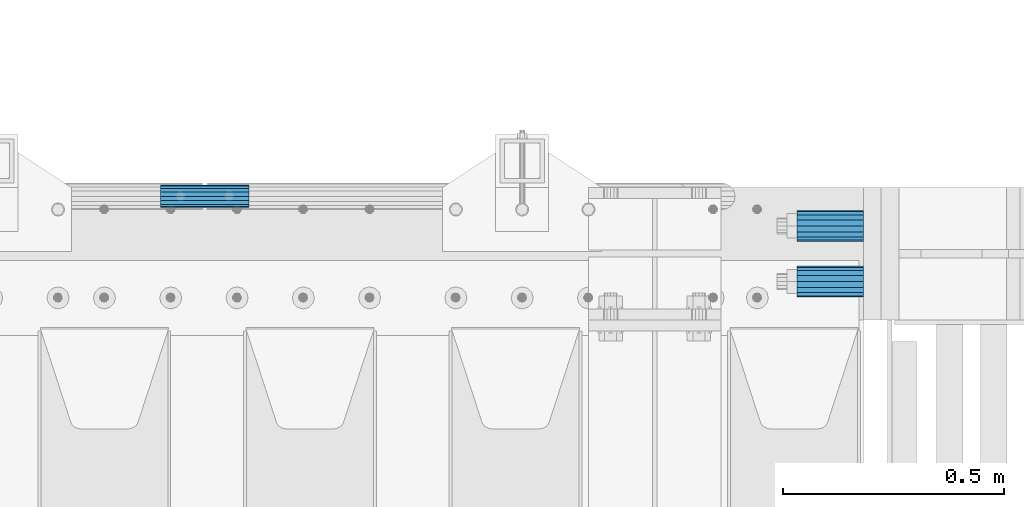
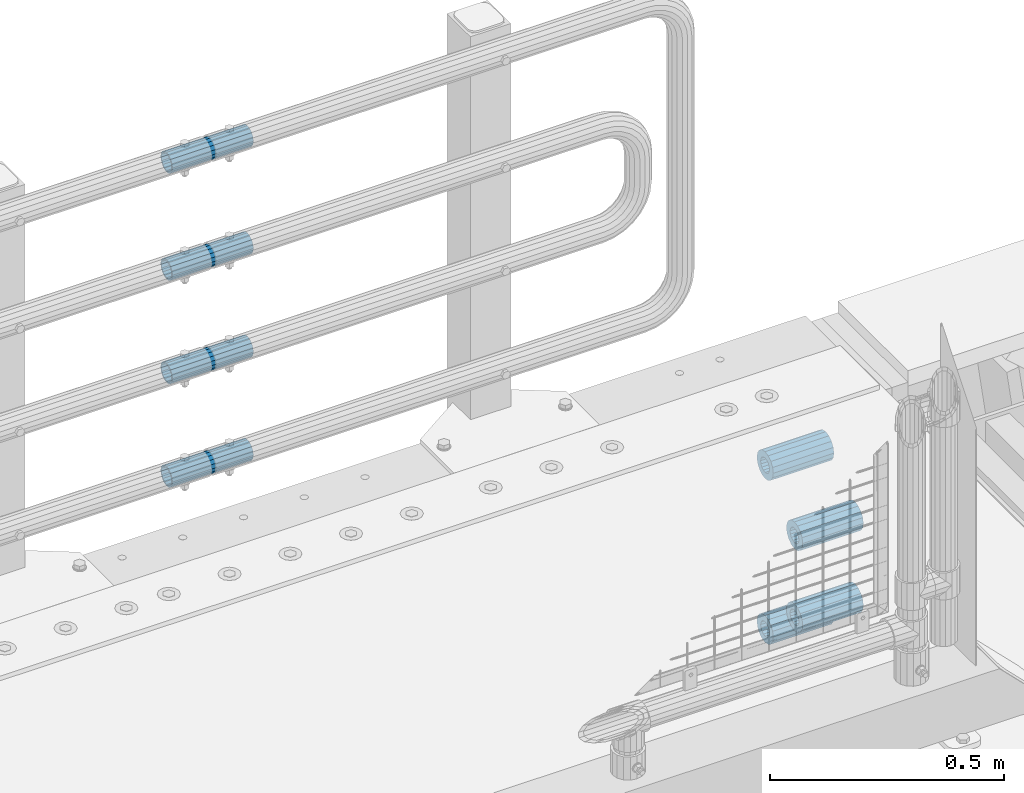
# One storey, part 176 of 257: 8 beams.
"""IFC2X3 building model written with IfcOpenShell, lengths in millimetres."""

from ifc_helpers import new_model, si_unit, frame, origin_with_axes, place, context, subcontext, project, spatial, faceted_brep, material, type_object, element, save


model = new_model("IFC2X3")

# Units and contexts
model_context = context("Model", 3, precision=1e-05, world=origin_with_axes())
body_context = subcontext(model_context, "Body", "Model", "MODEL_VIEW")
ifc_project = project(units=[si_unit("LENGTHUNIT", "METRE", prefix="MILLI"), si_unit("AREAUNIT", "SQUARE_METRE"), si_unit("VOLUMEUNIT", "CUBIC_METRE"), si_unit("MASSUNIT", "GRAM", prefix="KILO"), si_unit("TIMEUNIT", "SECOND"), si_unit("PLANEANGLEUNIT", "RADIAN"), si_unit("SOLIDANGLEUNIT", "STERADIAN"), si_unit("THERMODYNAMICTEMPERATUREUNIT", "DEGREE_CELSIUS"), si_unit("LUMINOUSINTENSITYUNIT", "LUMEN")], contexts=[model_context])

# Site, building, storey
site_placement = place(None, origin_with_axes())
site = spatial("IfcSite", under=ifc_project, at=site_placement, CompositionType="ELEMENT")
building_placement = place(site_placement, origin_with_axes())
building = spatial("IfcBuilding", under=site, at=building_placement, Name="Standard", CompositionType="ELEMENT")
storey_placement = place(building_placement, origin_with_axes())
storey = spatial("IfcBuildingStorey", under=building, at=storey_placement, Name="Undefined", CompositionType="ELEMENT", Elevation=0.0)

# Beams
ifc_material = material()
beam_type_1 = type_object("IfcBeamType", PredefinedType="NOTDEFINED")
beam_1_placement = place(storey_placement, frame((59117.0, 11937.0, -606.0), z_axis=(0.0, 0.0, 1.0), x_axis=(1.0, 0.0, 0.0)))
element("IfcBeam", 1, at=beam_1_placement, inside=storey, type_object=beam_type_1, material=ifc_material, context=body_context, shape_type="Brep", body=[
    faceted_brep([(-1.3120632047503e-07, -18.9999999995493, -6.27187546342611e-09), (0.0, -17.5537111177146, 7.27098521493672), (150.0, -17.5537111177146, 7.27098521493672), (150.0, -19.0, 0.0), (0.0, -13.4350288425449, 13.4350288425444), (150.0, -13.4350288425449, 13.4350288425444), (0.0, -7.27098521493645, 17.5537111177144), (150.0, -7.27098521493645, 17.5537111177144), (-6.33792751614237e-09, 4.50654624728486e-10, 18.9999999937208), (150.0, 0.0, 19.0), (0.0, 7.27098521493645, 17.5537111177144), (150.0, 7.27098521493645, 17.5537111177144), (0.0, 13.4350288425449, 13.4350288425444), (150.0, 13.4350288425449, 13.4350288425444), (0.0, 17.5537111177146, 7.2709852149367), (150.0, 17.5537111177146, 7.2709852149367), (1.33208345687308e-07, 19.0000000004507, -6.27187546342611e-09), (150.0, 19.0, 0.0), (0.0, 17.5537111177146, -7.2709852149367), (150.0, 17.5537111177146, -7.2709852149367), (0.0, 13.4350288425449, -13.4350288425444), (150.0, 13.4350288425449, -13.4350288425444), (0.0, 7.27098521493645, -17.5537111177144), (150.0, 7.27098521493645, -17.5537111177144), (8.33983904158231e-09, 4.50654624728486e-10, -19.0000000062719), (150.0, 0.0, -19.0), (0.0, -7.27098521493645, -17.5537111177144), (150.0, -7.27098521493645, -17.5537111177144), (0.0, -13.4350288425449, -13.4350288425444), (150.0, -13.4350288425449, -13.4350288425444), (0.0, -17.5537111177146, -7.2709852149367), (150.0, -17.5537111177146, -7.2709852149367), (7.27595761418343e-12, -35.0, 0.0), (1.45519152283669e-11, -32.335783637895, -13.3939201327781), (150.0, -32.3357836378955, -13.3939201327782), (150.0, -35.0, 0.0), (7.27595761418343e-12, -24.7487373415292, -24.748737341529), (150.0, -24.7487373415288, -24.7487373415292), (7.27595761418343e-12, -13.3939201327781, -32.335783637895), (150.0, -13.3939201327785, -32.335783637895), (7.27595761418343e-12, 0.0, -35.0), (150.0, 0.0, -35.0), (7.27595761418343e-12, 13.3939201327782, -32.335783637895), (150.0, 13.3939201327785, -32.335783637895), (7.27595761418343e-12, 24.7487373415292, -24.748737341529), (150.0, 24.7487373415288, -24.7487373415292), (1.45519152283669e-11, 32.335783637895, -13.3939201327781), (150.0, 32.3357836378955, -13.3939201327781), (7.27595761418343e-12, 35.0, 0.0), (150.0, 35.0, 0.0), (7.27595761418343e-12, 32.335783637895, 13.3939201327782), (150.0, 32.3357836378955, 13.3939201327781), (7.27595761418343e-12, 24.7487373415292, 24.7487373415291), (150.0, 24.7487373415288, 24.7487373415292), (1.45519152283669e-11, 13.3939201327781, 32.335783637895), (150.0, 13.3939201327785, 32.335783637895), (1.45519152283669e-11, 0.0, 35.0000000000001), (150.0, 0.0, 35.0), (1.45519152283669e-11, -13.3939201327781, 32.335783637895), (150.0, -13.3939201327785, 32.335783637895), (7.27595761418343e-12, -24.7487373415292, 24.7487373415291), (150.0, -24.7487373415288, 24.7487373415292), (7.27595761418343e-12, -32.335783637895, 13.3939201327782), (150.0, -32.3357836378955, 13.3939201327781)], [[[0, 1, 2, 3]], [[1, 4, 5, 2]], [[4, 6, 7, 5]], [[6, 8, 9, 7]], [[8, 10, 11, 9]], [[10, 12, 13, 11]], [[12, 14, 15, 13]], [[14, 16, 17, 15]], [[16, 18, 19, 17]], [[18, 20, 21, 19]], [[20, 22, 23, 21]], [[22, 24, 25, 23]], [[24, 26, 27, 25]], [[26, 28, 29, 27]], [[28, 30, 31, 29]], [[30, 0, 3, 31]], [[32, 33, 34, 35]], [[33, 36, 37, 34]], [[36, 38, 39, 37]], [[38, 40, 41, 39]], [[40, 42, 43, 41]], [[42, 44, 45, 43]], [[44, 46, 47, 45]], [[46, 48, 49, 47]], [[48, 50, 51, 49]], [[50, 52, 53, 51]], [[52, 54, 55, 53]], [[54, 56, 57, 55]], [[56, 58, 59, 57]], [[58, 60, 61, 59]], [[60, 62, 63, 61]], [[62, 32, 35, 63]], [[37, 39, 41, 43, 45, 47, 49, 51, 53, 55, 57, 59, 61, 63, 35, 34], [5, 7, 9, 11, 13, 15, 17, 19, 21, 23, 25, 27, 29, 31, 3, 2]], [[62, 60, 58, 56, 54, 52, 50, 48, 46, 44, 42, 40, 38, 36, 33, 32], [30, 28, 26, 24, 22, 20, 18, 16, 14, 12, 10, 8, 6, 4, 1, 0]]]),
])
beam_2_placement = place(storey_placement, frame((59117.0, 11937.0, -392.0), z_axis=(0.0, 0.0, 1.0), x_axis=(1.0, 0.0, 0.0)))
element("IfcBeam", 2, at=beam_2_placement, inside=storey, type_object=beam_type_1, material=ifc_material, context=body_context, shape_type="Brep", body=[
    faceted_brep([(-1.3120632047503e-07, -18.9999999995493, -6.27187546342611e-09), (0.0, -17.5537111177146, 7.27098521493672), (150.0, -17.5537111177146, 7.27098521493672), (150.0, -19.0, 0.0), (0.0, -13.4350288425449, 13.4350288425444), (150.0, -13.4350288425449, 13.4350288425444), (0.0, -7.27098521493645, 17.5537111177144), (150.0, -7.27098521493645, 17.5537111177144), (-6.33792751614237e-09, 4.50654624728486e-10, 18.9999999937208), (150.0, 0.0, 19.0), (0.0, 7.27098521493645, 17.5537111177144), (150.0, 7.27098521493645, 17.5537111177144), (0.0, 13.4350288425449, 13.4350288425444), (150.0, 13.4350288425449, 13.4350288425444), (0.0, 17.5537111177146, 7.2709852149367), (150.0, 17.5537111177146, 7.2709852149367), (1.33208345687308e-07, 19.0000000004507, -6.27187546342611e-09), (150.0, 19.0, 0.0), (0.0, 17.5537111177146, -7.2709852149367), (150.0, 17.5537111177146, -7.2709852149367), (0.0, 13.4350288425449, -13.4350288425444), (150.0, 13.4350288425449, -13.4350288425444), (0.0, 7.27098521493645, -17.5537111177144), (150.0, 7.27098521493645, -17.5537111177144), (8.33983904158231e-09, 4.50654624728486e-10, -19.0000000062719), (150.0, 0.0, -19.0), (0.0, -7.27098521493645, -17.5537111177144), (150.0, -7.27098521493645, -17.5537111177144), (0.0, -13.4350288425449, -13.4350288425444), (150.0, -13.4350288425449, -13.4350288425444), (0.0, -17.5537111177146, -7.2709852149367), (150.0, -17.5537111177146, -7.2709852149367), (7.27595761418343e-12, -35.0, 0.0), (1.45519152283669e-11, -32.335783637895, -13.3939201327781), (150.0, -32.3357836378955, -13.3939201327782), (150.0, -35.0, 0.0), (7.27595761418343e-12, -24.7487373415292, -24.748737341529), (150.0, -24.7487373415288, -24.7487373415292), (7.27595761418343e-12, -13.3939201327781, -32.335783637895), (150.0, -13.3939201327785, -32.335783637895), (7.27595761418343e-12, 0.0, -35.0), (150.0, 0.0, -35.0), (7.27595761418343e-12, 13.3939201327782, -32.335783637895), (150.0, 13.3939201327785, -32.335783637895), (7.27595761418343e-12, 24.7487373415292, -24.748737341529), (150.0, 24.7487373415288, -24.7487373415292), (1.45519152283669e-11, 32.335783637895, -13.3939201327781), (150.0, 32.3357836378955, -13.3939201327781), (7.27595761418343e-12, 35.0, 0.0), (150.0, 35.0, 0.0), (7.27595761418343e-12, 32.335783637895, 13.3939201327782), (150.0, 32.3357836378955, 13.3939201327781), (7.27595761418343e-12, 24.7487373415292, 24.7487373415291), (150.0, 24.7487373415288, 24.7487373415292), (1.45519152283669e-11, 13.3939201327781, 32.335783637895), (150.0, 13.3939201327785, 32.335783637895), (1.45519152283669e-11, 0.0, 35.0000000000001), (150.0, 0.0, 35.0), (1.45519152283669e-11, -13.3939201327781, 32.335783637895), (150.0, -13.3939201327785, 32.335783637895), (7.27595761418343e-12, -24.7487373415292, 24.7487373415291), (150.0, -24.7487373415288, 24.7487373415292), (7.27595761418343e-12, -32.335783637895, 13.3939201327782), (150.0, -32.3357836378955, 13.3939201327781)], [[[0, 1, 2, 3]], [[1, 4, 5, 2]], [[4, 6, 7, 5]], [[6, 8, 9, 7]], [[8, 10, 11, 9]], [[10, 12, 13, 11]], [[12, 14, 15, 13]], [[14, 16, 17, 15]], [[16, 18, 19, 17]], [[18, 20, 21, 19]], [[20, 22, 23, 21]], [[22, 24, 25, 23]], [[24, 26, 27, 25]], [[26, 28, 29, 27]], [[28, 30, 31, 29]], [[30, 0, 3, 31]], [[32, 33, 34, 35]], [[33, 36, 37, 34]], [[36, 38, 39, 37]], [[38, 40, 41, 39]], [[40, 42, 43, 41]], [[42, 44, 45, 43]], [[44, 46, 47, 45]], [[46, 48, 49, 47]], [[48, 50, 51, 49]], [[50, 52, 53, 51]], [[52, 54, 55, 53]], [[54, 56, 57, 55]], [[56, 58, 59, 57]], [[58, 60, 61, 59]], [[60, 62, 63, 61]], [[62, 32, 35, 63]], [[37, 39, 41, 43, 45, 47, 49, 51, 53, 55, 57, 59, 61, 63, 35, 34], [5, 7, 9, 11, 13, 15, 17, 19, 21, 23, 25, 27, 29, 31, 3, 2]], [[62, 60, 58, 56, 54, 52, 50, 48, 46, 44, 42, 40, 38, 36, 33, 32], [30, 28, 26, 24, 22, 20, 18, 16, 14, 12, 10, 8, 6, 4, 1, 0]]]),
])
beam_3_placement = place(storey_placement, frame((59117.0, 12063.0, -285.0), z_axis=(0.0, 0.0, 1.0), x_axis=(1.0, 0.0, 0.0)))
element("IfcBeam", 3, at=beam_3_placement, inside=storey, type_object=beam_type_1, material=ifc_material, context=body_context, shape_type="Brep", body=[
    faceted_brep([(-1.3120632047503e-07, -18.9999999995493, -6.27187546342611e-09), (0.0, -17.5537111177146, 7.27098521493672), (150.0, -17.5537111177146, 7.27098521493672), (150.0, -19.0, 0.0), (0.0, -13.4350288425449, 13.4350288425444), (150.0, -13.4350288425449, 13.4350288425444), (0.0, -7.27098521493645, 17.5537111177144), (150.0, -7.27098521493645, 17.5537111177144), (-6.33792751614237e-09, 4.50654624728486e-10, 18.9999999937208), (150.0, 0.0, 19.0), (0.0, 7.27098521493645, 17.5537111177144), (150.0, 7.27098521493645, 17.5537111177144), (0.0, 13.4350288425449, 13.4350288425444), (150.0, 13.4350288425449, 13.4350288425444), (0.0, 17.5537111177146, 7.2709852149367), (150.0, 17.5537111177146, 7.2709852149367), (1.33208345687308e-07, 19.0000000004507, -6.27187546342611e-09), (150.0, 19.0, 0.0), (0.0, 17.5537111177146, -7.2709852149367), (150.0, 17.5537111177146, -7.2709852149367), (0.0, 13.4350288425449, -13.4350288425444), (150.0, 13.4350288425449, -13.4350288425444), (0.0, 7.27098521493645, -17.5537111177144), (150.0, 7.27098521493645, -17.5537111177144), (8.33983904158231e-09, 4.50654624728486e-10, -19.0000000062719), (150.0, 0.0, -19.0), (0.0, -7.27098521493645, -17.5537111177144), (150.0, -7.27098521493645, -17.5537111177144), (0.0, -13.4350288425449, -13.4350288425444), (150.0, -13.4350288425449, -13.4350288425444), (0.0, -17.5537111177146, -7.2709852149367), (150.0, -17.5537111177146, -7.2709852149367), (7.27595761418343e-12, -35.0, 0.0), (1.45519152283669e-11, -32.335783637895, -13.3939201327781), (150.0, -32.3357836378955, -13.3939201327782), (150.0, -35.0, 0.0), (7.27595761418343e-12, -24.7487373415292, -24.748737341529), (150.0, -24.7487373415288, -24.7487373415292), (7.27595761418343e-12, -13.3939201327781, -32.335783637895), (150.0, -13.3939201327785, -32.335783637895), (7.27595761418343e-12, 0.0, -35.0), (150.0, 0.0, -35.0), (7.27595761418343e-12, 13.3939201327782, -32.335783637895), (150.0, 13.3939201327785, -32.335783637895), (7.27595761418343e-12, 24.7487373415292, -24.748737341529), (150.0, 24.7487373415288, -24.7487373415292), (1.45519152283669e-11, 32.335783637895, -13.3939201327781), (150.0, 32.3357836378955, -13.3939201327781), (7.27595761418343e-12, 35.0, 0.0), (150.0, 35.0, 0.0), (7.27595761418343e-12, 32.335783637895, 13.3939201327782), (150.0, 32.3357836378955, 13.3939201327781), (7.27595761418343e-12, 24.7487373415292, 24.7487373415291), (150.0, 24.7487373415288, 24.7487373415292), (1.45519152283669e-11, 13.3939201327781, 32.335783637895), (150.0, 13.3939201327785, 32.335783637895), (1.45519152283669e-11, 0.0, 35.0000000000001), (150.0, 0.0, 35.0), (1.45519152283669e-11, -13.3939201327781, 32.335783637895), (150.0, -13.3939201327785, 32.335783637895), (7.27595761418343e-12, -24.7487373415292, 24.7487373415291), (150.0, -24.7487373415288, 24.7487373415292), (7.27595761418343e-12, -32.335783637895, 13.3939201327782), (150.0, -32.3357836378955, 13.3939201327781)], [[[0, 1, 2, 3]], [[1, 4, 5, 2]], [[4, 6, 7, 5]], [[6, 8, 9, 7]], [[8, 10, 11, 9]], [[10, 12, 13, 11]], [[12, 14, 15, 13]], [[14, 16, 17, 15]], [[16, 18, 19, 17]], [[18, 20, 21, 19]], [[20, 22, 23, 21]], [[22, 24, 25, 23]], [[24, 26, 27, 25]], [[26, 28, 29, 27]], [[28, 30, 31, 29]], [[30, 0, 3, 31]], [[32, 33, 34, 35]], [[33, 36, 37, 34]], [[36, 38, 39, 37]], [[38, 40, 41, 39]], [[40, 42, 43, 41]], [[42, 44, 45, 43]], [[44, 46, 47, 45]], [[46, 48, 49, 47]], [[48, 50, 51, 49]], [[50, 52, 53, 51]], [[52, 54, 55, 53]], [[54, 56, 57, 55]], [[56, 58, 59, 57]], [[58, 60, 61, 59]], [[60, 62, 63, 61]], [[62, 32, 35, 63]], [[37, 39, 41, 43, 45, 47, 49, 51, 53, 55, 57, 59, 61, 63, 35, 34], [5, 7, 9, 11, 13, 15, 17, 19, 21, 23, 25, 27, 29, 31, 3, 2]], [[62, 60, 58, 56, 54, 52, 50, 48, 46, 44, 42, 40, 38, 36, 33, 32], [30, 28, 26, 24, 22, 20, 18, 16, 14, 12, 10, 8, 6, 4, 1, 0]]]),
])
beam_4_placement = place(storey_placement, frame((59117.0, 12063.0, -713.0), z_axis=(0.0, 0.0, 1.0), x_axis=(1.0, 0.0, 0.0)))
element("IfcBeam", 4, at=beam_4_placement, inside=storey, type_object=beam_type_1, material=ifc_material, context=body_context, shape_type="Brep", body=[
    faceted_brep([(-1.3120632047503e-07, -18.9999999995493, -6.27187546342611e-09), (0.0, -17.5537111177146, 7.27098521493672), (150.0, -17.5537111177146, 7.27098521493672), (150.0, -19.0, 0.0), (0.0, -13.4350288425449, 13.4350288425444), (150.0, -13.4350288425449, 13.4350288425444), (0.0, -7.27098521493645, 17.5537111177144), (150.0, -7.27098521493645, 17.5537111177144), (-6.33792751614237e-09, 4.50654624728486e-10, 18.9999999937208), (150.0, 0.0, 19.0), (0.0, 7.27098521493645, 17.5537111177144), (150.0, 7.27098521493645, 17.5537111177144), (0.0, 13.4350288425449, 13.4350288425444), (150.0, 13.4350288425449, 13.4350288425444), (0.0, 17.5537111177146, 7.2709852149367), (150.0, 17.5537111177146, 7.2709852149367), (1.33208345687308e-07, 19.0000000004507, -6.27187546342611e-09), (150.0, 19.0, 0.0), (0.0, 17.5537111177146, -7.2709852149367), (150.0, 17.5537111177146, -7.2709852149367), (0.0, 13.4350288425449, -13.4350288425444), (150.0, 13.4350288425449, -13.4350288425444), (0.0, 7.27098521493645, -17.5537111177144), (150.0, 7.27098521493645, -17.5537111177144), (8.33983904158231e-09, 4.50654624728486e-10, -19.0000000062719), (150.0, 0.0, -19.0), (0.0, -7.27098521493645, -17.5537111177144), (150.0, -7.27098521493645, -17.5537111177144), (0.0, -13.4350288425449, -13.4350288425444), (150.0, -13.4350288425449, -13.4350288425444), (0.0, -17.5537111177146, -7.2709852149367), (150.0, -17.5537111177146, -7.2709852149367), (7.27595761418343e-12, -35.0, 0.0), (1.45519152283669e-11, -32.335783637895, -13.3939201327781), (150.0, -32.3357836378955, -13.3939201327782), (150.0, -35.0, 0.0), (7.27595761418343e-12, -24.7487373415292, -24.748737341529), (150.0, -24.7487373415288, -24.7487373415292), (7.27595761418343e-12, -13.3939201327781, -32.335783637895), (150.0, -13.3939201327785, -32.335783637895), (7.27595761418343e-12, 0.0, -35.0), (150.0, 0.0, -35.0), (7.27595761418343e-12, 13.3939201327782, -32.335783637895), (150.0, 13.3939201327785, -32.335783637895), (7.27595761418343e-12, 24.7487373415292, -24.748737341529), (150.0, 24.7487373415288, -24.7487373415292), (1.45519152283669e-11, 32.335783637895, -13.3939201327781), (150.0, 32.3357836378955, -13.3939201327781), (7.27595761418343e-12, 35.0, 0.0), (150.0, 35.0, 0.0), (7.27595761418343e-12, 32.335783637895, 13.3939201327782), (150.0, 32.3357836378955, 13.3939201327781), (7.27595761418343e-12, 24.7487373415292, 24.7487373415291), (150.0, 24.7487373415288, 24.7487373415292), (1.45519152283669e-11, 13.3939201327781, 32.335783637895), (150.0, 13.3939201327785, 32.335783637895), (1.45519152283669e-11, 0.0, 35.0000000000001), (150.0, 0.0, 35.0), (1.45519152283669e-11, -13.3939201327781, 32.335783637895), (150.0, -13.3939201327785, 32.335783637895), (7.27595761418343e-12, -24.7487373415292, 24.7487373415291), (150.0, -24.7487373415288, 24.7487373415292), (7.27595761418343e-12, -32.335783637895, 13.3939201327782), (150.0, -32.3357836378955, 13.3939201327781)], [[[0, 1, 2, 3]], [[1, 4, 5, 2]], [[4, 6, 7, 5]], [[6, 8, 9, 7]], [[8, 10, 11, 9]], [[10, 12, 13, 11]], [[12, 14, 15, 13]], [[14, 16, 17, 15]], [[16, 18, 19, 17]], [[18, 20, 21, 19]], [[20, 22, 23, 21]], [[22, 24, 25, 23]], [[24, 26, 27, 25]], [[26, 28, 29, 27]], [[28, 30, 31, 29]], [[30, 0, 3, 31]], [[32, 33, 34, 35]], [[33, 36, 37, 34]], [[36, 38, 39, 37]], [[38, 40, 41, 39]], [[40, 42, 43, 41]], [[42, 44, 45, 43]], [[44, 46, 47, 45]], [[46, 48, 49, 47]], [[48, 50, 51, 49]], [[50, 52, 53, 51]], [[52, 54, 55, 53]], [[54, 56, 57, 55]], [[56, 58, 59, 57]], [[58, 60, 61, 59]], [[60, 62, 63, 61]], [[62, 32, 35, 63]], [[37, 39, 41, 43, 45, 47, 49, 51, 53, 55, 57, 59, 61, 63, 35, 34], [5, 7, 9, 11, 13, 15, 17, 19, 21, 23, 25, 27, 29, 31, 3, 2]], [[62, 60, 58, 56, 54, 52, 50, 48, 46, 44, 42, 40, 38, 36, 33, 32], [30, 28, 26, 24, 22, 20, 18, 16, 14, 12, 10, 8, 6, 4, 1, 0]]]),
])
beam_type_2 = type_object("IfcBeamType", PredefinedType="NOTDEFINED")
beam_5_placement = place(storey_placement, frame((57676.9975029999, 12129.8500000004, 419.849999999725), z_axis=(0.0, 0.0, 1.0), x_axis=(1.0, 0.0, 0.0)))
element("IfcBeam", 5, at=beam_5_placement, inside=storey, type_object=beam_type_2, material=ifc_material, context=body_context, shape_type="Brep", body=[
    faceted_brep([(0.0, -21.8999999999996, 0.0), (0.0, -20.232961761998, 8.38076716879547), (200.0, -20.232961761998, 8.38076716879547), (200.0, -21.8999999999996, 0.0), (0.0, -15.4856385079856, 15.4856385079854), (200.0, -15.4856385079856, 15.4856385079854), (0.0, -8.3807671687955, 20.2329617619972), (200.0, -8.3807671687955, 20.2329617619972), (0.0, 0.0, 21.9), (200.0, 0.0, 21.9), (0.0, 8.3807671687955, 20.2329617619972), (200.0, 8.3807671687955, 20.2329617619972), (0.0, 15.4856385079856, 15.4856385079854), (200.0, 15.4856385079856, 15.4856385079854), (0.0, 20.232961761998, 8.38076716879547), (200.0, 20.232961761998, 8.38076716879547), (0.0, 21.8999999999996, 0.0), (200.0, 21.8999999999996, 0.0), (0.0, 20.232961761998, -8.38076716879547), (200.0, 20.232961761998, -8.38076716879547), (0.0, 15.4856385079856, -15.4856385079854), (200.0, 15.4856385079856, -15.4856385079854), (0.0, 8.3807671687955, -20.2329617619972), (200.0, 8.3807671687955, -20.2329617619972), (0.0, 0.0, -21.9), (200.0, 0.0, -21.9), (0.0, -8.3807671687955, -20.2329617619972), (200.0, -8.3807671687955, -20.2329617619972), (0.0, -15.4856385079856, -15.4856385079854), (200.0, -15.4856385079856, -15.4856385079854), (0.0, -20.232961761998, -8.38076716879547), (200.0, -20.232961761998, -8.38076716879547), (0.0, -25.5, 0.0), (0.0, -23.5589280790373, -9.7584275253098), (200.0, -23.5589280790373, -9.7584275253098), (200.0, -25.5, 0.0), (0.0, -18.0312229202573, -18.031222920257), (200.0, -18.0312229202573, -18.031222920257), (0.0, -9.75842752531025, -23.5589280790378), (200.0, -9.75842752531025, -23.5589280790378), (0.0, 0.0, -25.5), (200.0, 0.0, -25.5), (0.0, 9.75842752531025, -23.5589280790378), (200.0, 9.75842752531025, -23.5589280790378), (0.0, 18.0312229202573, -18.031222920257), (200.0, 18.0312229202573, -18.031222920257), (0.0, 23.5589280790373, -9.7584275253098), (200.0, 23.5589280790373, -9.7584275253098), (0.0, 25.5, 0.0), (200.0, 25.5, 0.0), (0.0, 23.5589280790373, 9.7584275253098), (200.0, 23.5589280790373, 9.7584275253098), (0.0, 18.0312229202573, 18.031222920257), (200.0, 18.0312229202573, 18.031222920257), (0.0, 9.75842752531025, 23.5589280790378), (200.0, 9.75842752531025, 23.5589280790378), (0.0, 0.0, 25.5), (200.0, 0.0, 25.5), (0.0, -9.75842752531025, 23.5589280790378), (200.0, -9.75842752531025, 23.5589280790378), (0.0, -18.0312229202573, 18.031222920257), (200.0, -18.0312229202573, 18.031222920257), (0.0, -23.5589280790373, 9.7584275253098), (200.0, -23.5589280790373, 9.7584275253098)], [[[0, 1, 2, 3]], [[1, 4, 5, 2]], [[4, 6, 7, 5]], [[6, 8, 9, 7]], [[8, 10, 11, 9]], [[10, 12, 13, 11]], [[12, 14, 15, 13]], [[14, 16, 17, 15]], [[16, 18, 19, 17]], [[18, 20, 21, 19]], [[20, 22, 23, 21]], [[22, 24, 25, 23]], [[24, 26, 27, 25]], [[26, 28, 29, 27]], [[28, 30, 31, 29]], [[30, 0, 3, 31]], [[32, 33, 34, 35]], [[33, 36, 37, 34]], [[36, 38, 39, 37]], [[38, 40, 41, 39]], [[40, 42, 43, 41]], [[42, 44, 45, 43]], [[44, 46, 47, 45]], [[46, 48, 49, 47]], [[48, 50, 51, 49]], [[50, 52, 53, 51]], [[52, 54, 55, 53]], [[54, 56, 57, 55]], [[56, 58, 59, 57]], [[58, 60, 61, 59]], [[60, 62, 63, 61]], [[62, 32, 35, 63]], [[37, 39, 41, 43, 45, 47, 49, 51, 53, 55, 57, 59, 61, 63, 35, 34], [5, 7, 9, 11, 13, 15, 17, 19, 21, 23, 25, 27, 29, 31, 3, 2]], [[62, 60, 58, 56, 54, 52, 50, 48, 46, 44, 42, 40, 38, 36, 33, 32], [30, 28, 26, 24, 22, 20, 18, 16, 14, 12, 10, 8, 6, 4, 1, 0]]]),
])
beam_6_placement = place(storey_placement, frame((57676.9975029999, 12129.8500000004, 149.849999999725), z_axis=(0.0, 0.0, 1.0), x_axis=(1.0, 0.0, 0.0)))
element("IfcBeam", 6, at=beam_6_placement, inside=storey, type_object=beam_type_2, material=ifc_material, context=body_context, shape_type="Brep", body=[
    faceted_brep([(0.0, -21.8999999999996, 0.0), (0.0, -20.232961761998, 8.38076716879547), (200.0, -20.232961761998, 8.38076716879547), (200.0, -21.8999999999996, 0.0), (0.0, -15.4856385079856, 15.4856385079854), (200.0, -15.4856385079856, 15.4856385079854), (0.0, -8.3807671687955, 20.2329617619972), (200.0, -8.3807671687955, 20.2329617619972), (0.0, 0.0, 21.9), (200.0, 0.0, 21.9), (0.0, 8.3807671687955, 20.2329617619972), (200.0, 8.3807671687955, 20.2329617619972), (0.0, 15.4856385079856, 15.4856385079854), (200.0, 15.4856385079856, 15.4856385079854), (0.0, 20.232961761998, 8.38076716879547), (200.0, 20.232961761998, 8.38076716879547), (0.0, 21.8999999999996, 0.0), (200.0, 21.8999999999996, 0.0), (0.0, 20.232961761998, -8.38076716879547), (200.0, 20.232961761998, -8.38076716879547), (0.0, 15.4856385079856, -15.4856385079854), (200.0, 15.4856385079856, -15.4856385079854), (0.0, 8.3807671687955, -20.2329617619972), (200.0, 8.3807671687955, -20.2329617619972), (0.0, 0.0, -21.9), (200.0, 0.0, -21.9), (0.0, -8.3807671687955, -20.2329617619972), (200.0, -8.3807671687955, -20.2329617619972), (0.0, -15.4856385079856, -15.4856385079854), (200.0, -15.4856385079856, -15.4856385079854), (0.0, -20.232961761998, -8.38076716879547), (200.0, -20.232961761998, -8.38076716879547), (0.0, -25.5, 0.0), (0.0, -23.5589280790373, -9.7584275253098), (200.0, -23.5589280790373, -9.7584275253098), (200.0, -25.5, 0.0), (0.0, -18.0312229202573, -18.031222920257), (200.0, -18.0312229202573, -18.031222920257), (0.0, -9.75842752531025, -23.5589280790378), (200.0, -9.75842752531025, -23.5589280790378), (0.0, 0.0, -25.5), (200.0, 0.0, -25.5), (0.0, 9.75842752531025, -23.5589280790378), (200.0, 9.75842752531025, -23.5589280790378), (0.0, 18.0312229202573, -18.031222920257), (200.0, 18.0312229202573, -18.031222920257), (0.0, 23.5589280790373, -9.7584275253098), (200.0, 23.5589280790373, -9.7584275253098), (0.0, 25.5, 0.0), (200.0, 25.5, 0.0), (0.0, 23.5589280790373, 9.7584275253098), (200.0, 23.5589280790373, 9.7584275253098), (0.0, 18.0312229202573, 18.031222920257), (200.0, 18.0312229202573, 18.031222920257), (0.0, 9.75842752531025, 23.5589280790378), (200.0, 9.75842752531025, 23.5589280790378), (0.0, 0.0, 25.5), (200.0, 0.0, 25.5), (0.0, -9.75842752531025, 23.5589280790378), (200.0, -9.75842752531025, 23.5589280790378), (0.0, -18.0312229202573, 18.031222920257), (200.0, -18.0312229202573, 18.031222920257), (0.0, -23.5589280790373, 9.7584275253098), (200.0, -23.5589280790373, 9.7584275253098)], [[[0, 1, 2, 3]], [[1, 4, 5, 2]], [[4, 6, 7, 5]], [[6, 8, 9, 7]], [[8, 10, 11, 9]], [[10, 12, 13, 11]], [[12, 14, 15, 13]], [[14, 16, 17, 15]], [[16, 18, 19, 17]], [[18, 20, 21, 19]], [[20, 22, 23, 21]], [[22, 24, 25, 23]], [[24, 26, 27, 25]], [[26, 28, 29, 27]], [[28, 30, 31, 29]], [[30, 0, 3, 31]], [[32, 33, 34, 35]], [[33, 36, 37, 34]], [[36, 38, 39, 37]], [[38, 40, 41, 39]], [[40, 42, 43, 41]], [[42, 44, 45, 43]], [[44, 46, 47, 45]], [[46, 48, 49, 47]], [[48, 50, 51, 49]], [[50, 52, 53, 51]], [[52, 54, 55, 53]], [[54, 56, 57, 55]], [[56, 58, 59, 57]], [[58, 60, 61, 59]], [[60, 62, 63, 61]], [[62, 32, 35, 63]], [[37, 39, 41, 43, 45, 47, 49, 51, 53, 55, 57, 59, 61, 63, 35, 34], [5, 7, 9, 11, 13, 15, 17, 19, 21, 23, 25, 27, 29, 31, 3, 2]], [[62, 60, 58, 56, 54, 52, 50, 48, 46, 44, 42, 40, 38, 36, 33, 32], [30, 28, 26, 24, 22, 20, 18, 16, 14, 12, 10, 8, 6, 4, 1, 0]]]),
])
beam_7_placement = place(storey_placement, frame((57676.9975029999, 12129.8500000004, 689.849999999725), z_axis=(0.0, 0.0, 1.0), x_axis=(1.0, 0.0, 0.0)))
element("IfcBeam", 7, at=beam_7_placement, inside=storey, type_object=beam_type_2, material=ifc_material, context=body_context, shape_type="Brep", body=[
    faceted_brep([(0.0, -21.8999999999996, 0.0), (0.0, -20.232961761998, 8.38076716879547), (200.0, -20.232961761998, 8.38076716879547), (200.0, -21.8999999999996, 0.0), (0.0, -15.4856385079856, 15.4856385079854), (200.0, -15.4856385079856, 15.4856385079854), (0.0, -8.3807671687955, 20.2329617619972), (200.0, -8.3807671687955, 20.2329617619972), (0.0, 0.0, 21.9), (200.0, 0.0, 21.9), (0.0, 8.3807671687955, 20.2329617619972), (200.0, 8.3807671687955, 20.2329617619972), (0.0, 15.4856385079856, 15.4856385079854), (200.0, 15.4856385079856, 15.4856385079854), (0.0, 20.232961761998, 8.38076716879547), (200.0, 20.232961761998, 8.38076716879547), (0.0, 21.8999999999996, 0.0), (200.0, 21.8999999999996, 0.0), (0.0, 20.232961761998, -8.38076716879547), (200.0, 20.232961761998, -8.38076716879547), (0.0, 15.4856385079856, -15.4856385079854), (200.0, 15.4856385079856, -15.4856385079854), (0.0, 8.3807671687955, -20.2329617619972), (200.0, 8.3807671687955, -20.2329617619972), (0.0, 0.0, -21.9), (200.0, 0.0, -21.9), (0.0, -8.3807671687955, -20.2329617619972), (200.0, -8.3807671687955, -20.2329617619972), (0.0, -15.4856385079856, -15.4856385079854), (200.0, -15.4856385079856, -15.4856385079854), (0.0, -20.232961761998, -8.38076716879547), (200.0, -20.232961761998, -8.38076716879547), (0.0, -25.5, 0.0), (0.0, -23.5589280790373, -9.7584275253098), (200.0, -23.5589280790373, -9.7584275253098), (200.0, -25.5, 0.0), (0.0, -18.0312229202573, -18.031222920257), (200.0, -18.0312229202573, -18.031222920257), (0.0, -9.75842752531025, -23.5589280790378), (200.0, -9.75842752531025, -23.5589280790378), (0.0, 0.0, -25.5), (200.0, 0.0, -25.5), (0.0, 9.75842752531025, -23.5589280790378), (200.0, 9.75842752531025, -23.5589280790378), (0.0, 18.0312229202573, -18.031222920257), (200.0, 18.0312229202573, -18.031222920257), (0.0, 23.5589280790373, -9.7584275253098), (200.0, 23.5589280790373, -9.7584275253098), (0.0, 25.5, 0.0), (200.0, 25.5, 0.0), (0.0, 23.5589280790373, 9.7584275253098), (200.0, 23.5589280790373, 9.7584275253098), (0.0, 18.0312229202573, 18.031222920257), (200.0, 18.0312229202573, 18.031222920257), (0.0, 9.75842752531025, 23.5589280790378), (200.0, 9.75842752531025, 23.5589280790378), (0.0, 0.0, 25.5), (200.0, 0.0, 25.5), (0.0, -9.75842752531025, 23.5589280790378), (200.0, -9.75842752531025, 23.5589280790378), (0.0, -18.0312229202573, 18.031222920257), (200.0, -18.0312229202573, 18.031222920257), (0.0, -23.5589280790373, 9.7584275253098), (200.0, -23.5589280790373, 9.7584275253098)], [[[0, 1, 2, 3]], [[1, 4, 5, 2]], [[4, 6, 7, 5]], [[6, 8, 9, 7]], [[8, 10, 11, 9]], [[10, 12, 13, 11]], [[12, 14, 15, 13]], [[14, 16, 17, 15]], [[16, 18, 19, 17]], [[18, 20, 21, 19]], [[20, 22, 23, 21]], [[22, 24, 25, 23]], [[24, 26, 27, 25]], [[26, 28, 29, 27]], [[28, 30, 31, 29]], [[30, 0, 3, 31]], [[32, 33, 34, 35]], [[33, 36, 37, 34]], [[36, 38, 39, 37]], [[38, 40, 41, 39]], [[40, 42, 43, 41]], [[42, 44, 45, 43]], [[44, 46, 47, 45]], [[46, 48, 49, 47]], [[48, 50, 51, 49]], [[50, 52, 53, 51]], [[52, 54, 55, 53]], [[54, 56, 57, 55]], [[56, 58, 59, 57]], [[58, 60, 61, 59]], [[60, 62, 63, 61]], [[62, 32, 35, 63]], [[37, 39, 41, 43, 45, 47, 49, 51, 53, 55, 57, 59, 61, 63, 35, 34], [5, 7, 9, 11, 13, 15, 17, 19, 21, 23, 25, 27, 29, 31, 3, 2]], [[62, 60, 58, 56, 54, 52, 50, 48, 46, 44, 42, 40, 38, 36, 33, 32], [30, 28, 26, 24, 22, 20, 18, 16, 14, 12, 10, 8, 6, 4, 1, 0]]]),
])
beam_8_placement = place(storey_placement, frame((57676.9975029999, 12129.8500000005, 969.849999999725), z_axis=(0.0, 0.0, 1.0), x_axis=(1.0, 0.0, 0.0)))
element("IfcBeam", 8, at=beam_8_placement, inside=storey, type_object=beam_type_2, material=ifc_material, context=body_context, shape_type="Brep", body=[
    faceted_brep([(0.0, -21.8999999999996, 0.0), (0.0, -20.232961761998, 8.38076716879547), (200.0, -20.232961761998, 8.38076716879547), (200.0, -21.8999999999996, 0.0), (0.0, -15.4856385079856, 15.4856385079854), (200.0, -15.4856385079856, 15.4856385079854), (0.0, -8.3807671687955, 20.2329617619972), (200.0, -8.3807671687955, 20.2329617619972), (0.0, 0.0, 21.9), (200.0, 0.0, 21.9), (0.0, 8.3807671687955, 20.2329617619972), (200.0, 8.3807671687955, 20.2329617619972), (0.0, 15.4856385079856, 15.4856385079854), (200.0, 15.4856385079856, 15.4856385079854), (0.0, 20.232961761998, 8.38076716879547), (200.0, 20.232961761998, 8.38076716879547), (0.0, 21.8999999999996, 0.0), (200.0, 21.8999999999996, 0.0), (0.0, 20.232961761998, -8.38076716879547), (200.0, 20.232961761998, -8.38076716879547), (0.0, 15.4856385079856, -15.4856385079854), (200.0, 15.4856385079856, -15.4856385079854), (0.0, 8.3807671687955, -20.2329617619972), (200.0, 8.3807671687955, -20.2329617619972), (0.0, 0.0, -21.9), (200.0, 0.0, -21.9), (0.0, -8.3807671687955, -20.2329617619972), (200.0, -8.3807671687955, -20.2329617619972), (0.0, -15.4856385079856, -15.4856385079854), (200.0, -15.4856385079856, -15.4856385079854), (0.0, -20.232961761998, -8.38076716879547), (200.0, -20.232961761998, -8.38076716879547), (0.0, -25.5, 0.0), (0.0, -23.5589280790373, -9.7584275253098), (200.0, -23.5589280790373, -9.7584275253098), (200.0, -25.5, 0.0), (0.0, -18.0312229202573, -18.031222920257), (200.0, -18.0312229202573, -18.031222920257), (0.0, -9.75842752531025, -23.5589280790378), (200.0, -9.75842752531025, -23.5589280790378), (0.0, 0.0, -25.5), (200.0, 0.0, -25.5), (0.0, 9.75842752531025, -23.5589280790378), (200.0, 9.75842752531025, -23.5589280790378), (0.0, 18.0312229202573, -18.031222920257), (200.0, 18.0312229202573, -18.031222920257), (0.0, 23.5589280790373, -9.7584275253098), (200.0, 23.5589280790373, -9.7584275253098), (0.0, 25.5, 0.0), (200.0, 25.5, 0.0), (0.0, 23.5589280790373, 9.7584275253098), (200.0, 23.5589280790373, 9.7584275253098), (0.0, 18.0312229202573, 18.031222920257), (200.0, 18.0312229202573, 18.031222920257), (0.0, 9.75842752531025, 23.5589280790378), (200.0, 9.75842752531025, 23.5589280790378), (0.0, 0.0, 25.5), (200.0, 0.0, 25.5), (0.0, -9.75842752531025, 23.5589280790378), (200.0, -9.75842752531025, 23.5589280790378), (0.0, -18.0312229202573, 18.031222920257), (200.0, -18.0312229202573, 18.031222920257), (0.0, -23.5589280790373, 9.7584275253098), (200.0, -23.5589280790373, 9.7584275253098)], [[[0, 1, 2, 3]], [[1, 4, 5, 2]], [[4, 6, 7, 5]], [[6, 8, 9, 7]], [[8, 10, 11, 9]], [[10, 12, 13, 11]], [[12, 14, 15, 13]], [[14, 16, 17, 15]], [[16, 18, 19, 17]], [[18, 20, 21, 19]], [[20, 22, 23, 21]], [[22, 24, 25, 23]], [[24, 26, 27, 25]], [[26, 28, 29, 27]], [[28, 30, 31, 29]], [[30, 0, 3, 31]], [[32, 33, 34, 35]], [[33, 36, 37, 34]], [[36, 38, 39, 37]], [[38, 40, 41, 39]], [[40, 42, 43, 41]], [[42, 44, 45, 43]], [[44, 46, 47, 45]], [[46, 48, 49, 47]], [[48, 50, 51, 49]], [[50, 52, 53, 51]], [[52, 54, 55, 53]], [[54, 56, 57, 55]], [[56, 58, 59, 57]], [[58, 60, 61, 59]], [[60, 62, 63, 61]], [[62, 32, 35, 63]], [[37, 39, 41, 43, 45, 47, 49, 51, 53, 55, 57, 59, 61, 63, 35, 34], [5, 7, 9, 11, 13, 15, 17, 19, 21, 23, 25, 27, 29, 31, 3, 2]], [[62, 60, 58, 56, 54, 52, 50, 48, 46, 44, 42, 40, 38, 36, 33, 32], [30, 28, 26, 24, 22, 20, 18, 16, 14, 12, 10, 8, 6, 4, 1, 0]]]),
])

save(model, "model.ifc")
